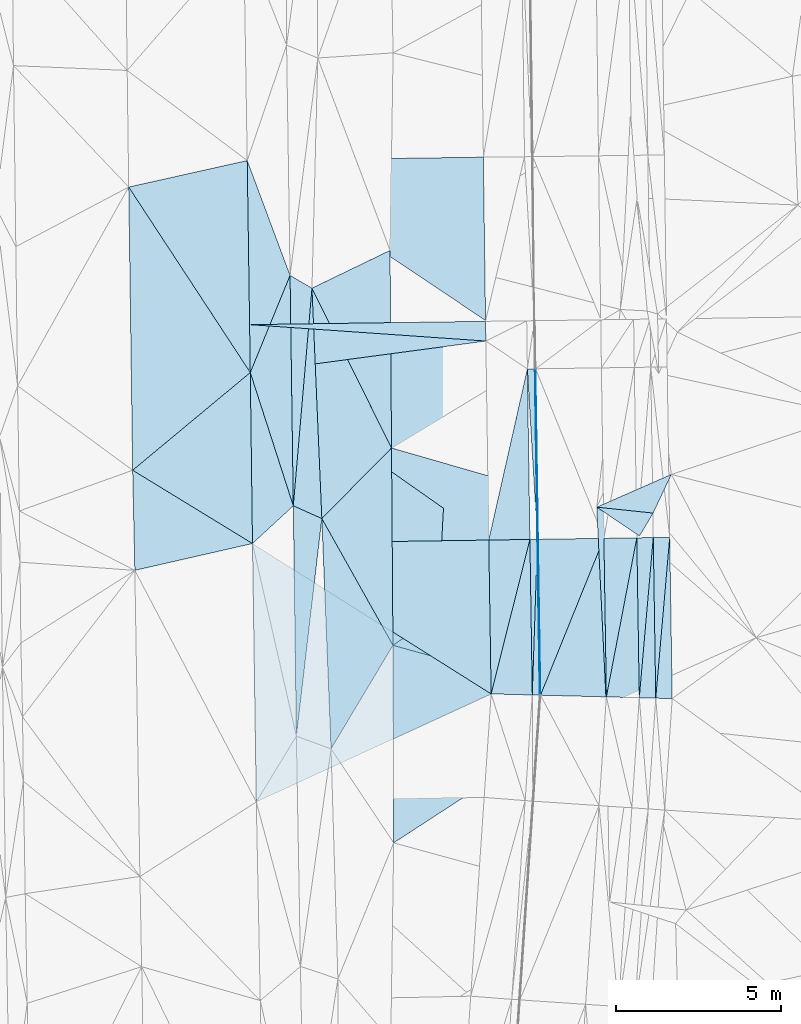
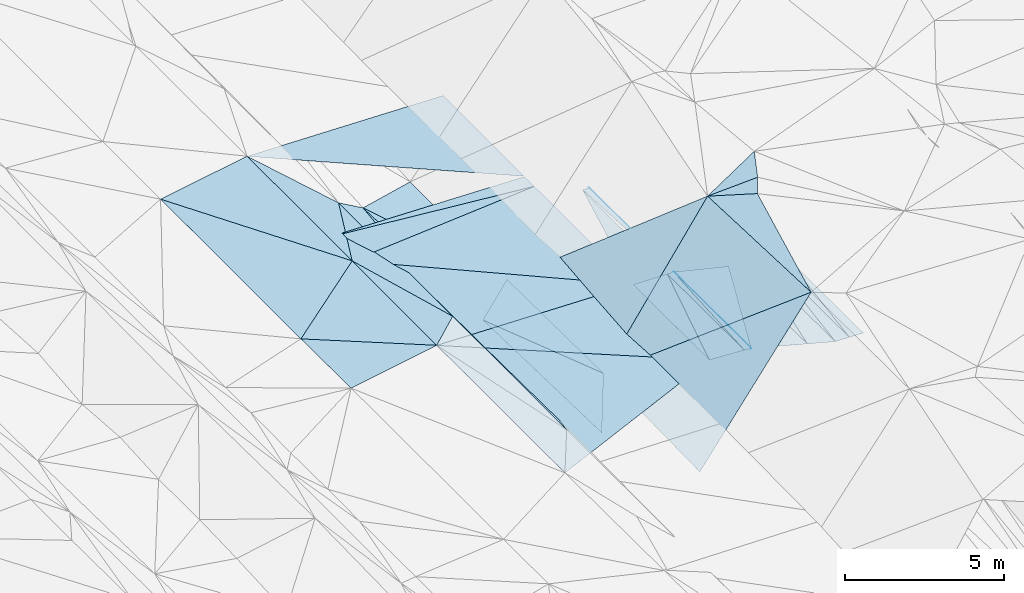
# One storey, part 27 of 275: 45 plates.
"""IFC2X3 building model written with IfcOpenShell, lengths in millimetres."""

from ifc_helpers import new_model, si_unit, frame, origin_with_axes, place, context, subcontext, project, spatial, polyline, outline, extrude, material, type_object, element, save


model = new_model("IFC2X3")

# Units and contexts
model_context = context("Model", 3, precision=1e-05, world=origin_with_axes())
body_context = subcontext(model_context, "Body", "Model", "MODEL_VIEW")
ifc_project = project(units=[si_unit("LENGTHUNIT", "METRE", prefix="MILLI"), si_unit("AREAUNIT", "SQUARE_METRE"), si_unit("VOLUMEUNIT", "CUBIC_METRE"), si_unit("MASSUNIT", "GRAM", prefix="KILO"), si_unit("TIMEUNIT", "SECOND"), si_unit("PLANEANGLEUNIT", "RADIAN"), si_unit("SOLIDANGLEUNIT", "STERADIAN"), si_unit("THERMODYNAMICTEMPERATUREUNIT", "DEGREE_CELSIUS"), si_unit("LUMINOUSINTENSITYUNIT", "LUMEN")], contexts=[model_context])

# Site, building, storey
site_placement = place(None, origin_with_axes())
site = spatial("IfcSite", under=ifc_project, at=site_placement, CompositionType="ELEMENT")
building_placement = place(site_placement, origin_with_axes())
building = spatial("IfcBuilding", under=site, at=building_placement, Name="Undefined", CompositionType="ELEMENT")
storey_placement = place(building_placement, origin_with_axes())
storey = spatial("IfcBuildingStorey", under=building, at=storey_placement, Name="Undefined", CompositionType="ELEMENT", Elevation=0.0)

# Plates
ifc_material = material()
plate_type_1 = type_object("IfcPlateType", PredefinedType="NOTDEFINED")
plate_1_placement = place(storey_placement, frame((-64210.159760053, 189.124785894485, 41187.9714091792), z_axis=(-0.0344591553817913, 0.0214122371396731, -0.999176702446093), x_axis=(0.999317283927566, 0.0140672160391664, -0.0341625449365255)))
element("IfcPlate", 1, at=plate_1_placement, inside=storey, type_object=plate_type_1, material=ifc_material, Name="00_PR", context=body_context, shape_type="SweptSolid", body=[
    extrude(outline(polyline([(0.0, 0.0), (7176.6611328125, -1.23327481560409e-08), (7177.1123046875, 600.144226074219), (0.0, 0.0)])), frame((-8.85201319254618e-08, 2.18876761149539e-07, -0.5000001331573), z_axis=(0.0, 0.0, 1.0), x_axis=(1.0, 0.0, 0.0)), (0.0, 0.0, 1.0), 1.0),
])
plate_type_2 = type_object("IfcPlateType", PredefinedType="NOTDEFINED")
plate_2_placement = place(storey_placement, frame((-55517.9191393694, -1152.88491821365, 40855.2377286035), z_axis=(-0.0502327388667435, 0.019881716459408, -0.998539628305544), x_axis=(0.01464619705233, -0.999679663372047, -0.0206412100482138)))
element("IfcPlate", 2, at=plate_2_placement, inside=storey, type_object=plate_type_2, material=ifc_material, Name="00_PR", context=body_context, shape_type="SweptSolid", body=[
    extrude(outline(polyline([(0.0, 0.0), (5183.8046875, 3.20142135024071e-10), (5183.79248046875, 20.0249271392822), (0.0, 0.0)])), frame((-8.85201319254618e-08, 2.18876761149539e-07, -0.5000001331573), z_axis=(0.0, 0.0, 1.0), x_axis=(1.0, 0.0, 0.0)), (0.0, 0.0, 1.0), 1.0),
])
plate_3_placement = place(storey_placement, frame((-55441.9953571351, -6335.03027195838, 40748.2376657525), z_axis=(-0.0487154722957368, 0.0171894255625469, -0.998664771786726), x_axis=(0.0154761660437744, -0.999718878816224, -0.0179625060338716)))
element("IfcPlate", 3, at=plate_3_placement, inside=storey, type_object=plate_type_2, material=ifc_material, Name="00_PR", context=body_context, shape_type="SweptSolid", body=[
    extrude(outline(polyline([(0.0, 0.0), (4738.5927734375, 4.22005541622639e-10), (4737.74951171875, 20.0235061645508), (0.0, 0.0)])), frame((-8.85201319254618e-08, 2.18876761149539e-07, -0.5000001331573), z_axis=(0.0, 0.0, 1.0), x_axis=(1.0, 0.0, 0.0)), (0.0, 0.0, 1.0), 1.0),
])
plate_4_placement = place(storey_placement, frame((-55388.6712330053, -11071.7747794304, 40664.1057018536), z_axis=(-0.050194462781834, 0.0171714800845319, -0.998591836626832), x_axis=(-0.0154761530537114, 0.999718766430796, 0.0179687710416013)))
element("IfcPlate", 4, at=plate_4_placement, inside=storey, type_object=plate_type_2, material=ifc_material, Name="00_PR", context=body_context, shape_type="SweptSolid", body=[
    extrude(outline(polyline([(0.0, 0.0), (4737.775390625, -3.56521923094988e-09), (4737.74951171875, 20.0249137878418), (0.0, 0.0)])), frame((-8.85201319254618e-08, 2.18876761149539e-07, -0.5000001331573), z_axis=(0.0, 0.0, 1.0), x_axis=(1.0, 0.0, 0.0)), (0.0, 0.0, 1.0), 1.0),
])
plate_5_placement = place(storey_placement, frame((-55461.9937776422, -6335.33061844975, 40749.2377282403), z_axis=(-0.0502152544718577, 0.0198819235549548, -0.998540503602173), x_axis=(-0.0146461610550057, 0.999679665323876, 0.0206411410608503)))
element("IfcPlate", 5, at=plate_5_placement, inside=storey, type_object=plate_type_2, material=ifc_material, Name="00_PR", context=body_context, shape_type="SweptSolid", body=[
    extrude(outline(polyline([(0.0, 0.0), (5183.822265625, 2.73576006293297e-09), (5183.79248046875, 20.0247211456299), (0.0, 0.0)])), frame((-8.85201319254618e-08, 2.18876761149539e-07, -0.5000001331573), z_axis=(0.0, 0.0, 1.0), x_axis=(1.0, 0.0, 0.0)), (0.0, 0.0, 1.0), 1.0),
])
plate_type_3 = type_object("IfcPlateType", PredefinedType="NOTDEFINED")
plate_6_placement = place(storey_placement, frame((-56869.455881822, -11033.5873581353, 40714.7573721092), z_axis=(-0.0340942846838589, 0.0183376643510045, -0.999250373939408), x_axis=(-0.0154706520409419, 0.999702174722167, 0.0188738120473266)))
element("IfcPlate", 6, at=plate_6_placement, inside=storey, type_object=plate_type_3, material=ifc_material, Name="00_PR", context=body_context, shape_type="SweptSolid", body=[
    extrude(outline(polyline([(0.0, 0.0), (4677.32763671875, -1.70985003933311e-09), (4676.04052734375, 1250.71484375), (0.0, 0.0)])), frame((-8.85201319254618e-08, 2.18876761149539e-07, -0.5000001331573), z_axis=(0.0, 0.0, 1.0), x_axis=(1.0, 0.0, 0.0)), (0.0, 0.0, 1.0), 1.0),
])
plate_type_4 = type_object("IfcPlateType", PredefinedType="NOTDEFINED")
plate_7_placement = place(storey_placement, frame((-55691.9577699752, -6338.80032935777, 40760.7373147765), z_axis=(-0.0309697079540327, 0.0175551254943787, -0.999366146493926), x_axis=(0.0154752810397423, -0.999717481506153, -0.0180408660472688)))
element("IfcPlate", 7, at=plate_7_placement, inside=storey, type_object=plate_type_4, material=ifc_material, Name="00_PR", context=body_context, shape_type="SweptSolid", body=[
    extrude(outline(polyline([(0.0, 0.0), (4728.37646484375, -3.97267285734415e-09), (4676.068359375, 1250.60974121094), (0.0, 0.0)])), frame((-8.85201319254618e-08, 2.18876761149539e-07, -0.5000001331573), z_axis=(0.0, 0.0, 1.0), x_axis=(1.0, 0.0, 0.0)), (0.0, 0.0, 1.0), 1.0),
])
plate_type_5 = type_object("IfcPlateType", PredefinedType="NOTDEFINED")
plate_8_placement = place(storey_placement, frame((-51442.4250776583, -6274.70013917776, 39998.2370705365), z_axis=(0.00113251728802259, 0.0167995025517689, -0.99985823701093), x_axis=(0.0154903480468549, -0.999739207072914, -0.0167799570502322)))
element("IfcPlate", 8, at=plate_8_placement, inside=storey, type_object=plate_type_5, material=ifc_material, Name="00_PR", context=body_context, shape_type="SweptSolid", body=[
    extrude(outline(polyline([(0.0, 0.0), (4902.03857421875, 8.14907252788544e-10), (4881.40478515625, 500.008575439453), (0.0, 0.0)])), frame((-8.85201319254618e-08, 2.18876761149539e-07, -0.5000001331573), z_axis=(0.0, 0.0, 1.0), x_axis=(1.0, 0.0, 0.0)), (0.0, 0.0, 1.0), 1.0),
])
plate_9_placement = place(storey_placement, frame((-51866.759363512, -11162.5664392091, 39915.6310710457), z_axis=(-0.000255211503644943, 0.0169199528402176, -0.999856814780483), x_axis=(-0.0154887200483178, 0.999736840204551, 0.0169218760509593)))
element("IfcPlate", 9, at=plate_9_placement, inside=storey, type_object=plate_type_5, material=ifc_material, Name="00_PR", context=body_context, shape_type="SweptSolid", body=[
    extrude(outline(polyline([(0.0, 0.0), (4881.6103515625, -1.08411768451333e-09), (4881.40576171875, 500.000305175781), (0.0, 0.0)])), frame((-8.85201319254618e-08, 2.18876761149539e-07, -0.5000001331573), z_axis=(0.0, 0.0, 1.0), x_axis=(1.0, 0.0, 0.0)), (0.0, 0.0, 1.0), 1.0),
])
plate_10_placement = place(storey_placement, frame((-52367.028154363, -11149.6728333864, 39915.2790714769), z_axis=(-0.000257407842764711, 0.01706346001216, -0.999854375433551), x_axis=(-0.015486809048846, 0.99973443016982, 0.0170654000395729)))
element("IfcPlate", 10, at=plate_10_placement, inside=storey, type_object=plate_type_5, material=ifc_material, Name="00_PR", context=body_context, shape_type="SweptSolid", body=[
    extrude(outline(polyline([(0.0, 0.0), (4861.18115234375, 1.01863406598568e-10), (4860.978515625, 499.999908447266), (0.0, 0.0)])), frame((-8.85201319254618e-08, 2.18876761149539e-07, -0.5000001331573), z_axis=(0.0, 0.0, 1.0), x_axis=(1.0, 0.0, 0.0)), (0.0, 0.0, 1.0), 1.0),
])
plate_type_6 = type_object("IfcPlateType", PredefinedType="NOTDEFINED")
plate_11_placement = place(storey_placement, frame((-55537.9168680056, -1153.16914689851, 40856.2377285437), z_axis=(-0.0502152544718577, 0.0198819235549548, -0.998540503602173), x_axis=(0.01464619705233, -0.999679663372047, -0.0206412100482138)))
element("IfcPlate", 11, at=plate_11_placement, inside=storey, type_object=plate_type_6, material=ifc_material, Name="00_PR", context=body_context, shape_type="SweptSolid", body=[
    extrude(outline(polyline([(0.0, 0.0), (5183.822265625, 2.73576006293297e-09), (-0.336663156747818, 230.287506103516), (0.0, 0.0)])), frame((-8.85201319254618e-08, 2.18876761149539e-07, -0.5000001331573), z_axis=(0.0, 0.0, 1.0), x_axis=(1.0, 0.0, 0.0)), (0.0, 0.0, 1.0), 1.0),
])
plate_12_placement = place(storey_placement, frame((-55461.9930281349, -6335.33196187845, 40749.2376661681), z_axis=(-0.048716670435588, 0.0171956650293007, -0.998664605924267), x_axis=(0.0154761530566903, -0.999718766430248, -0.0179687710695483)))
element("IfcPlate", 12, at=plate_12_placement, inside=storey, type_object=plate_type_6, material=ifc_material, Name="00_PR", context=body_context, shape_type="SweptSolid", body=[
    extrude(outline(polyline([(0.0, 0.0), (4737.775390625, -3.56521923094988e-09), (4728.078125, 230.274154663086), (0.0, 0.0)])), frame((-8.85201319254618e-08, 2.18876761149539e-07, -0.5000001331573), z_axis=(0.0, 0.0, 1.0), x_axis=(1.0, 0.0, 0.0)), (0.0, 0.0, 1.0), 1.0),
])
plate_13_placement = place(storey_placement, frame((-55618.7944288952, -11065.8408741252, 40675.4337026469), z_axis=(-0.0501953294415692, 0.0172435231682458, -0.99859055163315), x_axis=(-0.015475281042487, 0.999717481506, 0.0180408660533731)))
element("IfcPlate", 13, at=plate_13_placement, inside=storey, type_object=plate_type_6, material=ifc_material, Name="00_PR", context=body_context, shape_type="SweptSolid", body=[
    extrude(outline(polyline([(0.0, 0.0), (4728.37646484375, -3.97267285734415e-09), (4728.07763671875, 230.286895751953), (0.0, 0.0)])), frame((-8.85201319254618e-08, 2.18876761149539e-07, -0.5000001331573), z_axis=(0.0, 0.0, 1.0), x_axis=(1.0, 0.0, 0.0)), (0.0, 0.0, 1.0), 1.0),
])
plate_type_7 = type_object("IfcPlateType", PredefinedType="NOTDEFINED")
plate_14_placement = place(storey_placement, frame((-55767.8860055098, -1156.43906275371, 40867.7373907411), z_axis=(-0.0341201356917173, 0.0201308617974868, -0.999214974239112), x_axis=(0.01464619705233, -0.999679663372047, -0.0206412100482138)))
element("IfcPlate", 14, at=plate_14_placement, inside=storey, type_object=plate_type_7, material=ifc_material, Name="00_PR", context=body_context, shape_type="SweptSolid", body=[
    extrude(outline(polyline([(0.0, 0.0), (5184.0205078125, 4.80213202536106e-10), (5183.6884765625, 1250.71545410156), (0.0, 0.0)])), frame((-8.85201319254618e-08, 2.18876761149539e-07, -0.5000001331573), z_axis=(0.0, 0.0, 1.0), x_axis=(1.0, 0.0, 0.0)), (0.0, 0.0, 1.0), 1.0),
])
plate_15_placement = place(storey_placement, frame((-64189.1585967666, -1266.61869898646, 41159.5004384264), z_axis=(-0.0374323880602854, 0.0197390072792734, -0.999104192722527), x_axis=(0.379142535572972, 0.925329303371839, 0.00407652311232451)))
element("IfcPlate", 15, at=plate_15_placement, inside=storey, type_object=plate_type_7, material=ifc_material, Name="00", context=body_context, shape_type="SweptSolid", body=[
    extrude(outline(polyline([(0.0, 0.0), (3188.99194335938, -3.45607986673713e-09), (-3252.67822265625, 2747.79516601563), (0.0, 0.0)])), frame((-8.85201319254618e-08, 2.18876761149539e-07, -0.5000001331573), z_axis=(0.0, 0.0, 1.0), x_axis=(1.0, 0.0, 0.0)), (0.0, 0.0, 1.0), 1.0),
])
plate_type_8 = type_object("IfcPlateType", PredefinedType="NOTDEFINED")
plate_16_placement = place(storey_placement, frame((-64282.1043498937, 5175.9483709372, 41294.4214083389), z_axis=(-0.0341321768155963, 0.0212948019256935, -0.999190435260854), x_axis=(0.999323625483533, 0.0144173130710043, -0.0338294639960543)))
element("IfcPlate", 16, at=plate_16_placement, inside=storey, type_object=plate_type_8, material=ifc_material, Name="00_PR", context=body_context, shape_type="SweptSolid", body=[
    extrude(outline(polyline([(0.0, 0.0), (7180.9296875, -1.59561750479043e-08), (7180.2529296875, 4968.55810546875), (0.0, 0.0)])), frame((-8.85201319254618e-08, 2.18876761149539e-07, -0.5000001331573), z_axis=(0.0, 0.0, 1.0), x_axis=(1.0, 0.0, 0.0)), (0.0, 0.0, 1.0), 1.0),
])
plate_type_9 = type_object("IfcPlateType", PredefinedType="NOTDEFINED")
plate_17_placement = place(storey_placement, frame((-51942.3685599427, -6282.24095147888, 39998.2370712502), z_axis=(0.00114015911351522, 0.0169415543827888, -0.999855831493866), x_axis=(0.0154887200510319, -0.999736840204643, -0.0169218760430716)))
element("IfcPlate", 17, at=plate_17_placement, inside=storey, type_object=plate_type_9, material=ifc_material, Name="00_PR", context=body_context, shape_type="SweptSolid", body=[
    extrude(outline(polyline([(0.0, 0.0), (4881.6103515625, -1.08411768451333e-09), (4860.9775390625, 500.009521484375), (0.0, 0.0)])), frame((-8.85201319254618e-08, 2.18876761149539e-07, -0.5000001331573), z_axis=(0.0, 0.0, 1.0), x_axis=(1.0, 0.0, 0.0)), (0.0, 0.0, 1.0), 1.0),
])
plate_type_10 = type_object("IfcPlateType", PredefinedType="NOTDEFINED")
plate_18_placement = place(storey_placement, frame((-52442.4329270503, -6289.78480981317, 39998.2518321697), z_axis=(-0.241432313423507, 0.0128235090286059, -0.970332930313697), x_axis=(0.0154868090513612, -0.999734430169764, -0.0170654000405356)))
element("IfcPlate", 18, at=plate_18_placement, inside=storey, type_object=plate_type_10, material=ifc_material, Name="00_PR", context=body_context, shape_type="SweptSolid", body=[
    extrude(outline(polyline([(0.0, 0.0), (4861.18115234375, 1.01863406598568e-10), (4815.6484375, 1030.44067382813), (0.0, 0.0)])), frame((-8.85201319254618e-08, 2.18876761149539e-07, -0.5000001331573), z_axis=(0.0, 0.0, 1.0), x_axis=(1.0, 0.0, 0.0)), (0.0, 0.0, 1.0), 1.0),
])
plate_type_11 = type_object("IfcPlateType", PredefinedType="NOTDEFINED")
plate_19_placement = place(storey_placement, frame((-59941.2622952948, 2444.97051163059, 40453.5128494941), z_axis=(-0.224712652799255, 0.0165149287945518, -0.974285112684594), x_axis=(0.00738750555787057, -0.999798756878162, -0.0186512869935284)))
element("IfcPlate", 19, at=plate_19_placement, inside=storey, type_object=plate_type_11, material=ifc_material, Name="00", context=body_context, shape_type="SweptSolid", body=[
    extrude(outline(polyline([(0.0, 0.0), (6004.947265625, 1.33877620100975e-09), (1120.14624023438, 2444.45947265625), (0.0, 0.0)])), frame((-8.85201319254618e-08, 2.18876761149539e-07, -0.5000001331573), z_axis=(0.0, 0.0, 1.0), x_axis=(1.0, 0.0, 0.0)), (0.0, 0.0, 1.0), 1.0),
])
plate_type_12 = type_object("IfcPlateType", PredefinedType="NOTDEFINED")
plate_20_placement = place(storey_placement, frame((-53367.6850359296, -11123.8847143884, 40164.5819949225), z_axis=(-0.242726692369667, 0.0130824862071042, -0.970006495527696), x_axis=(-0.0154832380479063, 0.999729452120178, 0.017357762040118)))
element("IfcPlate", 20, at=plate_20_placement, inside=storey, type_object=plate_type_12, material=ifc_material, Name="00_PR", context=body_context, shape_type="SweptSolid", body=[
    extrude(outline(polyline([(0.0, 0.0), (4820.32177734375, 2.10275175049901e-09), (4815.5791015625, 1030.76489257813), (0.0, 0.0)])), frame((-8.85201319254618e-08, 2.18876761149539e-07, -0.5000001331573), z_axis=(0.0, 0.0, 1.0), x_axis=(1.0, 0.0, 0.0)), (0.0, 0.0, 1.0), 1.0),
])
plate_type_13 = type_object("IfcPlateType", PredefinedType="NOTDEFINED")
plate_21_placement = place(storey_placement, frame((-53442.3192306588, -6304.86666469064, 40248.2519997523), z_axis=(-0.242732931923578, 0.0136708427232228, -0.969996820520058), x_axis=(-0.373438587039186, -0.924162041207736, 0.0804247679569413)))
element("IfcPlate", 21, at=plate_21_placement, inside=storey, type_object=plate_type_13, material=ifc_material, Name="00_PR", context=body_context, shape_type="SweptSolid", body=[
    extrude(outline(polyline([(0.0, 0.0), (5158.64697265625, -7.34871719032526e-10), (814.882507324219, 1893.66552734375), (0.0, 0.0)])), frame((-8.85201319254618e-08, 2.18876761149539e-07, -0.5000001331573), z_axis=(0.0, 0.0, 1.0), x_axis=(1.0, 0.0, 0.0)), (0.0, 0.0, 1.0), 1.0),
])
plate_type_14 = type_object("IfcPlateType", PredefinedType="NOTDEFINED")
plate_22_placement = place(storey_placement, frame((-53442.3185710412, -6304.86694614279, 40248.2518318015), z_axis=(-0.241413838999191, 0.0131085003321077, -0.970333718654936), x_axis=(0.0154832380502641, -0.99972945212005, -0.017357762045344)))
element("IfcPlate", 22, at=plate_22_placement, inside=storey, type_object=plate_type_14, material=ifc_material, Name="00_PR", context=body_context, shape_type="SweptSolid", body=[
    extrude(outline(polyline([(0.0, 0.0), (4820.32177734375, 2.10275175049901e-09), (4729.10693359375, 2060.87036132813), (0.0, 0.0)])), frame((-8.85201319254618e-08, 2.18876761149539e-07, -0.5000001331573), z_axis=(0.0, 0.0, 1.0), x_axis=(1.0, 0.0, 0.0)), (0.0, 0.0, 1.0), 1.0),
])
plate_type_15 = type_object("IfcPlateType", PredefinedType="NOTDEFINED")
plate_23_placement = place(storey_placement, frame((-57029.9508478422, -309.8607816517, 40929.6504040799), z_axis=(-0.0345005852661392, 0.0208217875785176, -0.999187751515364), x_axis=(-0.990697748759906, -0.132396999013831, 0.0314484539236077)))
element("IfcPlate", 23, at=plate_23_placement, inside=storey, type_object=plate_type_15, material=ifc_material, Name="00_PR", context=body_context, shape_type="SweptSolid", body=[
    extrude(outline(polyline([(0.0, 0.0), (7226.42822265625, -1.24400685308501e-08), (7055.4765625, 1446.15637207031), (0.0, 0.0)])), frame((-8.85201319254618e-08, 2.18876761149539e-07, -0.5000001331573), z_axis=(0.0, 0.0, 1.0), x_axis=(1.0, 0.0, 0.0)), (0.0, 0.0, 1.0), 1.0),
])
plate_type_16 = type_object("IfcPlateType", PredefinedType="NOTDEFINED")
plate_24_placement = place(storey_placement, frame((-64189.1570396514, -1266.61840131675, 41156.9103984279), z_axis=(-0.0344467868815465, 0.0204168000354578, -0.99919796494481), x_axis=(0.990697748759891, 0.132396999013884, -0.0314484539238771)))
element("IfcPlate", 24, at=plate_24_placement, inside=storey, type_object=plate_type_16, material=ifc_material, Name="00_PR", context=body_context, shape_type="SweptSolid", body=[
    extrude(outline(polyline([(0.0, 0.0), (7226.42822265625, -1.24400685308501e-08), (6517.01416015625, 6008.02001953125), (0.0, 0.0)])), frame((-8.85201319254618e-08, 2.18876761149539e-07, -0.5000001331573), z_axis=(0.0, 0.0, 1.0), x_axis=(1.0, 0.0, 0.0)), (0.0, 0.0, 1.0), 1.0),
])
plate_type_17 = type_object("IfcPlateType", PredefinedType="NOTDEFINED")
plate_25_placement = place(storey_placement, frame((-56941.8171973827, -6357.65158554085, 40803.0363977641), z_axis=(-0.0341164932849878, 0.0208871014826681, -0.999199576599984), x_axis=(-0.999320002135611, -0.0147036730477608, 0.0338132419413773)))
element("IfcPlate", 25, at=plate_25_placement, inside=storey, type_object=plate_type_17, material=ifc_material, Name="00_PR", context=body_context, shape_type="SweptSolid", body=[
    extrude(outline(polyline([(0.0, 0.0), (7185.26171875, -7.44967110222206e-09), (7179.52001953125, 5198.294921875), (0.0, 0.0)])), frame((-8.85201319254618e-08, 2.18876761149539e-07, -0.5000001331573), z_axis=(0.0, 0.0, 1.0), x_axis=(1.0, 0.0, 0.0)), (0.0, 0.0, 1.0), 1.0),
])
plate_type_18 = type_object("IfcPlateType", PredefinedType="NOTDEFINED")
plate_26_placement = place(storey_placement, frame((-64122.1930756825, -6463.30259922524, 41045.9933715444), z_axis=(-0.0340807192152991, 0.0183378830184231, -0.999250832686253), x_axis=(0.999320002135719, 0.0147036730473772, -0.0338132419383676)))
element("IfcPlate", 26, at=plate_26_placement, inside=storey, type_object=plate_type_18, material=ifc_material, Name="00_PR", context=body_context, shape_type="SweptSolid", body=[
    extrude(outline(polyline([(0.0, 0.0), (7185.26171875, -7.44967110222206e-09), (7191.8056640625, 4677.32275390625), (0.0, 0.0)])), frame((-8.85201319254618e-08, 2.18876761149539e-07, -0.5000001331573), z_axis=(0.0, 0.0, 1.0), x_axis=(1.0, 0.0, 0.0)), (0.0, 0.0, 1.0), 1.0),
])
plate_type_19 = type_object("IfcPlateType", PredefinedType="NOTDEFINED")
plate_27_placement = place(storey_placement, frame((-56869.4550833881, -11033.5861015661, 40714.7573700239), z_axis=(-0.0324977319601621, 0.0208502294127109, -0.99925430464466), x_axis=(-0.908266557760662, -0.417873681938189, 0.0208193659130021)))
element("IfcPlate", 27, at=plate_27_placement, inside=storey, type_object=plate_type_19, material=ifc_material, Name="00_PR", context=body_context, shape_type="SweptSolid", body=[
    extrude(outline(polyline([(0.0, 0.0), (7858.02001953125, 2.17332853935659e-08), (4684.51318359375, 7187.1240234375), (0.0, 0.0)])), frame((-8.85201319254618e-08, 2.18876761149539e-07, -0.5000001331573), z_axis=(0.0, 0.0, 1.0), x_axis=(1.0, 0.0, 0.0)), (0.0, 0.0, 1.0), 1.0),
])
plate_type_20 = type_object("IfcPlateType", PredefinedType="NOTDEFINED")
plate_28_placement = place(storey_placement, frame((-62014.6374349437, -5703.18765621406, 40821.5083006353), z_axis=(-0.180562183860203, 0.0189158915987081, -0.983381658769707), x_axis=(0.486506367519403, -0.867221596794756, -0.106010642936589)))
element("IfcPlate", 28, at=plate_28_placement, inside=storey, type_object=plate_type_20, material=ifc_material, Name="00", context=body_context, shape_type="SweptSolid", body=[
    extrude(outline(polyline([(0.0, 0.0), (4442.9501953125, -5.40603650733829e-09), (6226.95458984375, 3216.91040039063), (0.0, 0.0)])), frame((-8.85201319254618e-08, 2.18876761149539e-07, -0.5000001331573), z_axis=(0.0, 0.0, 1.0), x_axis=(1.0, 0.0, 0.0)), (0.0, 0.0, 1.0), 1.0),
])
plate_type_21 = type_object("IfcPlateType", PredefinedType="NOTDEFINED")
plate_29_placement = place(storey_placement, frame((-62881.9435141206, -5316.87264253361, 41030.51826287), z_axis=(-0.267408157528486, 0.0157886556218717, -0.9634539924879), x_axis=(-0.0140288554992505, 0.999695985142317, 0.0202763039954012)))
element("IfcPlate", 29, at=plate_29_placement, inside=storey, type_object=plate_type_21, material=ifc_material, Name="00", context=body_context, shape_type="SweptSolid", body=[
    extrude(outline(polyline([(0.0, 0.0), (7003.2490234375, 4.36557456851006e-11), (6603.123046875, 684.699584960938), (0.0, 0.0)])), frame((-8.85201319254618e-08, 2.18876761149539e-07, -0.5000001331573), z_axis=(0.0, 0.0, 1.0), x_axis=(1.0, 0.0, 0.0)), (0.0, 0.0, 1.0), 1.0),
])
plate_type_22 = type_object("IfcPlateType", PredefinedType="NOTDEFINED")
plate_30_placement = place(storey_placement, frame((-51946.875239441, -5537.25336881453, 42669.5046275689), z_axis=(0.135830723117124, 0.00468440546043444, -0.990720985445934), x_axis=(-0.509066901450737, -0.857553013360627, -0.0738493000877678)))
element("IfcPlate", 30, at=plate_30_placement, inside=storey, type_object=plate_type_22, material=ifc_material, Name="00", context=body_context, shape_type="SweptSolid", body=[
    extrude(outline(polyline([(0.0, 0.0), (812.465393066406, -6.25732354819775e-10), (735.157470703125, 1575.05065917969), (0.0, 0.0)])), frame((-8.85201319254618e-08, 2.18876761149539e-07, -0.5000001331573), z_axis=(0.0, 0.0, 1.0), x_axis=(1.0, 0.0, 0.0)), (0.0, 0.0, 1.0), 1.0),
])
plate_type_23 = type_object("IfcPlateType", PredefinedType="NOTDEFINED")
plate_31_placement = place(storey_placement, frame((-62788.9518860476, -12315.9514007616, 40896.5131836665), z_axis=(-0.227673028649534, 0.0156158981736707, -0.973612415568833), x_axis=(-0.0132798234971424, 0.99972861305414, 0.0191401810004617)))
element("IfcPlate", 31, at=plate_31_placement, inside=storey, type_object=plate_type_23, material=ifc_material, Name="00", context=body_context, shape_type="SweptSolid", body=[
    extrude(outline(polyline([(0.0, 0.0), (7000.978515625, -2.94676283374429e-09), (6599.24951171875, 885.2568359375), (0.0, 0.0)])), frame((-8.85201319254618e-08, 2.18876761149539e-07, -0.5000001331573), z_axis=(0.0, 0.0, 1.0), x_axis=(1.0, 0.0, 0.0)), (0.0, 0.0, 1.0), 1.0),
])
plate_type_24 = type_object("IfcPlateType", PredefinedType="NOTDEFINED")
plate_32_placement = place(storey_placement, frame((-51394.2519242041, -4363.57706762689, 42759.5047052153), z_axis=(0.136542243290212, 0.011668089630461, -0.990565531139486), x_axis=(-0.424968872590862, -0.902558248668826, -0.0692102961177986)))
element("IfcPlate", 32, at=plate_32_placement, inside=storey, type_object=plate_type_24, material=ifc_material, Name="00", context=body_context, shape_type="SweptSolid", body=[
    extrude(outline(polyline([(0.0, 0.0), (1300.38452148438, 1.41153577715158e-09), (1882.31237792969, 1637.86474609375), (0.0, 0.0)])), frame((-8.85201319254618e-08, 2.18876761149539e-07, -0.5000001331573), z_axis=(0.0, 0.0, 1.0), x_axis=(1.0, 0.0, 0.0)), (0.0, 0.0, 1.0), 1.0),
])
plate_type_25 = type_object("IfcPlateType", PredefinedType="NOTDEFINED")
plate_33_placement = place(storey_placement, frame((-62314.8633888919, 1297.20843876065, 40981.5133215272), z_axis=(-0.229028848030111, 0.0124249483881698, -0.973340334840569), x_axis=(0.0428329705578776, -0.998821394399744, -0.0228289010365881)))
element("IfcPlate", 33, at=plate_33_placement, inside=storey, type_object=plate_type_25, material=ifc_material, Name="00", context=body_context, shape_type="SweptSolid", body=[
    extrude(outline(polyline([(0.0, 0.0), (7008.65966796875, -1.65891833603382e-09), (6580.8798828125, 872.966369628906), (0.0, 0.0)])), frame((-8.85201319254618e-08, 2.18876761149539e-07, -0.5000001331573), z_axis=(0.0, 0.0, 1.0), x_axis=(1.0, 0.0, 0.0)), (0.0, 0.0, 1.0), 1.0),
])
plate_type_26 = type_object("IfcPlateType", PredefinedType="NOTDEFINED")
plate_34_placement = place(storey_placement, frame((-64282.1077637136, 5175.94830935646, 41299.5005186181), z_axis=(-0.0408017894172617, 0.0211188728834411, -0.998944046074895), x_axis=(0.34918931743567, -0.936432988616277, -0.0340599239576074)))
element("IfcPlate", 34, at=plate_34_placement, inside=storey, type_object=plate_type_26, material=ifc_material, Name="00", context=body_context, shape_type="SweptSolid", body=[
    extrude(outline(polyline([(0.0, 0.0), (3728.72241210938, -1.86992110684514e-09), (6070.25634765625, 2164.92236328125), (0.0, 0.0)])), frame((-8.85201319254618e-08, 2.18876761149539e-07, -0.5000001331573), z_axis=(0.0, 0.0, 1.0), x_axis=(1.0, 0.0, 0.0)), (0.0, 0.0, 1.0), 1.0),
])
plate_type_27 = type_object("IfcPlateType", PredefinedType="NOTDEFINED")
plate_35_placement = place(storey_placement, frame((-62314.8652777636, 1297.20834744292, 40981.5137687865), z_axis=(-0.232806139586148, 0.0122425264152333, -0.972446102320312), x_axis=(0.442663860323383, -0.888999792403433, -0.117166871897539)))
element("IfcPlate", 35, at=plate_35_placement, inside=storey, type_object=plate_type_27, material=ifc_material, Name="00", context=body_context, shape_type="SweptSolid", body=[
    extrude(outline(polyline([(0.0, 0.0), (5462.294921875, 7.07223080098629e-09), (6374.98876953125, 2912.1865234375), (0.0, 0.0)])), frame((-8.85201319254618e-08, 2.18876761149539e-07, -0.5000001331573), z_axis=(0.0, 0.0, 1.0), x_axis=(1.0, 0.0, 0.0)), (0.0, 0.0, 1.0), 1.0),
])
plate_type_28 = type_object("IfcPlateType", PredefinedType="NOTDEFINED")
plate_36_placement = place(storey_placement, frame((-53370.4424629898, -11358.9895865065, 42289.5061606684), z_axis=(0.153458615955808, 0.0314262406949868, -0.987655225564422), x_axis=(-0.0481462096683657, 0.998544863385078, 0.0242919390301871)))
element("IfcPlate", 36, at=plate_36_placement, inside=storey, type_object=plate_type_28, material=ifc_material, Name="00", context=body_context, shape_type="SweptSolid", body=[
    extrude(outline(polyline([(0.0, 0.0), (6010.22412109375, 4.85306372866035e-09), (5076.70654296875, 1270.94689941406), (0.0, 0.0)])), frame((-8.85201319254618e-08, 2.18876761149539e-07, -0.5000001331573), z_axis=(0.0, 0.0, 1.0), x_axis=(1.0, 0.0, 0.0)), (0.0, 0.0, 1.0), 1.0),
])
plate_type_29 = type_object("IfcPlateType", PredefinedType="NOTDEFINED")
plate_37_placement = place(storey_placement, frame((-64189.1568685387, -1266.6182059191, 41159.5003832658), z_axis=(-0.0339736152249529, 0.0207128049142323, -0.999208073016392), x_axis=(0.012881915676595, -0.999693090218921, -0.0211608510473079)))
element("IfcPlate", 37, at=plate_37_placement, inside=storey, type_object=plate_type_29, material=ifc_material, Name="00", context=body_context, shape_type="SweptSolid", body=[
    extrude(outline(polyline([(0.0, 0.0), (5198.2783203125, 3.78349795937538e-10), (2920.73608398438, 3614.7890625), (0.0, 0.0)])), frame((-8.85201319254618e-08, 2.18876761149539e-07, -0.5000001331573), z_axis=(0.0, 0.0, 1.0), x_axis=(1.0, 0.0, 0.0)), (0.0, 0.0, 1.0), 1.0),
])
plate_type_30 = type_object("IfcPlateType", PredefinedType="NOTDEFINED")
plate_38_placement = place(storey_placement, frame((-59896.8974081154, -3558.77827965653, 40341.512030726), z_axis=(-0.218102576970182, -0.00305605096256415, -0.97592106569716), x_axis=(0.00729702954819284, -0.999972250397671, 0.00150059801058876)))
element("IfcPlate", 38, at=plate_38_placement, inside=storey, type_object=plate_type_30, material=ifc_material, Name="00", context=body_context, shape_type="SweptSolid", body=[
    extrude(outline(polyline([(0.0, 0.0), (5997.60888671875, 1.16415321826935e-09), (2129.62768554688, 2185.98413085938), (0.0, 0.0)])), frame((-8.85201319254618e-08, 2.18876761149539e-07, -0.5000001331573), z_axis=(0.0, 0.0, 1.0), x_axis=(1.0, 0.0, 0.0)), (0.0, 0.0, 1.0), 1.0),
])
plate_type_31 = type_object("IfcPlateType", PredefinedType="NOTDEFINED")
plate_39_placement = place(storey_placement, frame((-67763.9340289488, -4235.5843961127, 41219.5003831178), z_axis=(-0.0330228524770372, 0.0222669385255581, -0.99920652252824), x_axis=(0.852376116385588, -0.521413207445039, -0.0397897388443241)))
element("IfcPlate", 39, at=plate_39_placement, inside=storey, type_object=plate_type_31, material=ifc_material, Name="00", context=body_context, shape_type="SweptSolid", body=[
    extrude(outline(polyline([(0.0, 0.0), (4272.45849609375, 1.99215719476342e-08), (1645.86743164063, 2561.44897460938), (0.0, 0.0)])), frame((-8.85201319254618e-08, 2.18876761149539e-07, -0.5000001331573), z_axis=(0.0, 0.0, 1.0), x_axis=(1.0, 0.0, 0.0)), (0.0, 0.0, 1.0), 1.0),
])
plate_type_32 = type_object("IfcPlateType", PredefinedType="NOTDEFINED")
plate_40_placement = place(storey_placement, frame((-67884.1095401807, 4370.74130661037, 41399.5003756966), z_axis=(-0.0337368818258837, 0.0204274865385063, -0.99922196763201), x_axis=(0.547835849211173, -0.835828734088748, -0.0355838388973541)))
element("IfcPlate", 40, at=plate_40_placement, inside=storey, type_object=plate_type_32, material=ifc_material, Name="00", context=body_context, shape_type="SweptSolid", body=[
    extrude(outline(polyline([(0.0, 0.0), (6744.634765625, 5.85714587941766e-09), (7265.65625, 4618.00146484375), (0.0, 0.0)])), frame((-8.85201319254618e-08, 2.18876761149539e-07, -0.5000001331573), z_axis=(0.0, 0.0, 1.0), x_axis=(1.0, 0.0, 0.0)), (0.0, 0.0, 1.0), 1.0),
])
plate_type_33 = type_object("IfcPlateType", PredefinedType="NOTDEFINED")
plate_41_placement = place(storey_placement, frame((-64282.1036102889, 5175.94837852983, 41299.500364452), z_axis=(-0.0324906560236815, 0.0212453447112458, -0.999246212201603), x_axis=(0.0144221846793212, -0.999659996346374, -0.0217230820521418)))
element("IfcPlate", 41, at=plate_41_placement, inside=storey, type_object=plate_type_33, material=ifc_material, Name="00", context=body_context, shape_type="SweptSolid", body=[
    extrude(outline(polyline([(0.0, 0.0), (6444.75732421875, 2.09547579288483e-09), (750.811767578125, 3615.11840820313), (0.0, 0.0)])), frame((-8.85201319254618e-08, 2.18876761149539e-07, -0.5000001331573), z_axis=(0.0, 0.0, 1.0), x_axis=(1.0, 0.0, 0.0)), (0.0, 0.0, 1.0), 1.0),
])
plate_type_34 = type_object("IfcPlateType", PredefinedType="NOTDEFINED")
plate_42_placement = place(storey_placement, frame((-62881.8270242237, -5316.87019009628, 41030.5003948334), z_axis=(-0.0344439540636553, 0.02070640617786, -0.999192103037078), x_axis=(-0.734320795616484, -0.678709395373484, 0.0112483668562888)))
element("IfcPlate", 42, at=plate_42_placement, inside=storey, type_object=plate_type_34, material=ifc_material, Name="00", context=body_context, shape_type="SweptSolid", body=[
    extrude(outline(polyline([(0.0, 0.0), (1689.13415527344, -1.83354131877422e-09), (-1787.49340820313, 3864.60375976563), (0.0, 0.0)])), frame((-8.85201319254618e-08, 2.18876761149539e-07, -0.5000001331573), z_axis=(0.0, 0.0, 1.0), x_axis=(1.0, 0.0, 0.0)), (0.0, 0.0, 1.0), 1.0),
])
plate_type_35 = type_object("IfcPlateType", PredefinedType="NOTDEFINED")
plate_43_placement = place(storey_placement, frame((-59830.4469736527, -15559.8018291772, 40206.5220273355), z_axis=(0.292611276832146, 0.0240218174110052, -0.955929700845692), x_axis=(-0.00373505256653499, 0.999705495487077, 0.0239785669977213)))
element("IfcPlate", 43, at=plate_43_placement, inside=storey, type_object=plate_type_35, material=ifc_material, Name="00", context=body_context, shape_type="SweptSolid", body=[
    extrude(outline(polyline([(0.0, 0.0), (6005.36279296875, -3.41970007866621e-09), (4225.39013671875, 6772.31982421875), (0.0, 0.0)])), frame((-8.85201319254618e-08, 2.18876761149539e-07, -0.5000001331573), z_axis=(0.0, 0.0, 1.0), x_axis=(1.0, 0.0, 0.0)), (0.0, 0.0, 1.0), 1.0),
])
plate_type_36 = type_object("IfcPlateType", PredefinedType="NOTDEFINED")
plate_44_placement = place(storey_placement, frame((-59852.8643657692, -9556.21897582542, 40350.526033707), z_axis=(0.318517172468345, 0.000901812385681381, -0.947916661725698), x_axis=(-0.00729702956100898, 0.999972250397569, -0.00150059801655424)))
element("IfcPlate", 44, at=plate_44_placement, inside=storey, type_object=plate_type_36, material=ifc_material, Name="00", context=body_context, shape_type="SweptSolid", body=[
    extrude(outline(polyline([(0.0, 0.0), (5997.60888671875, 1.16415321826935e-09), (4150.255859375, 6565.55712890625), (0.0, 0.0)])), frame((-8.85201319254618e-08, 2.18876761149539e-07, -0.5000001331573), z_axis=(0.0, 0.0, 1.0), x_axis=(1.0, 0.0, 0.0)), (0.0, 0.0, 1.0), 1.0),
])
plate_type_37 = type_object("IfcPlateType", PredefinedType="NOTDEFINED")
plate_45_placement = place(storey_placement, frame((-53659.7408001361, -5357.50796390184, 42435.5227553076), z_axis=(0.295921541899864, 0.0374881319174235, -0.954476338630219), x_axis=(0.0481462095793285, -0.99854486339026, -0.0242919389936532)))
element("IfcPlate", 45, at=plate_45_placement, inside=storey, type_object=plate_type_37, material=ifc_material, Name="00", context=body_context, shape_type="SweptSolid", body=[
    extrude(outline(polyline([(0.0, 0.0), (6010.22412109375, 4.85306372866035e-09), (3945.0556640625, 6690.86669921875), (0.0, 0.0)])), frame((-8.85201319254618e-08, 2.18876761149539e-07, -0.5000001331573), z_axis=(0.0, 0.0, 1.0), x_axis=(1.0, 0.0, 0.0)), (0.0, 0.0, 1.0), 1.0),
])

save(model, "model.ifc")
